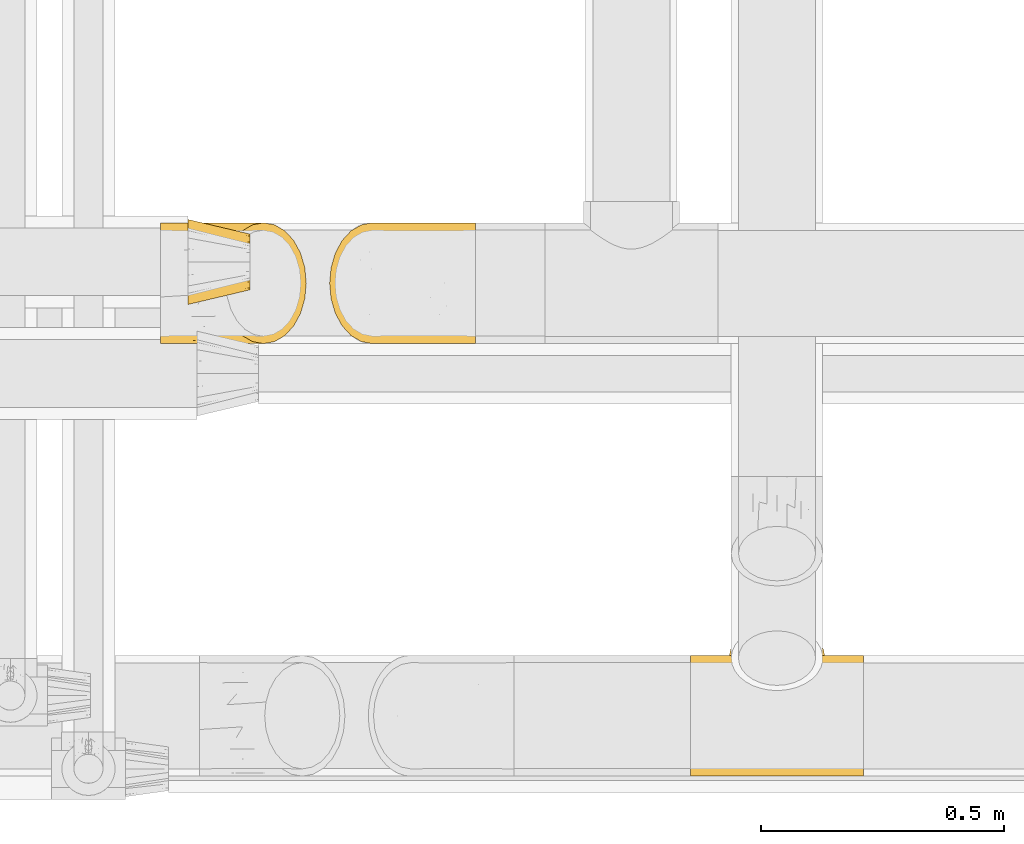
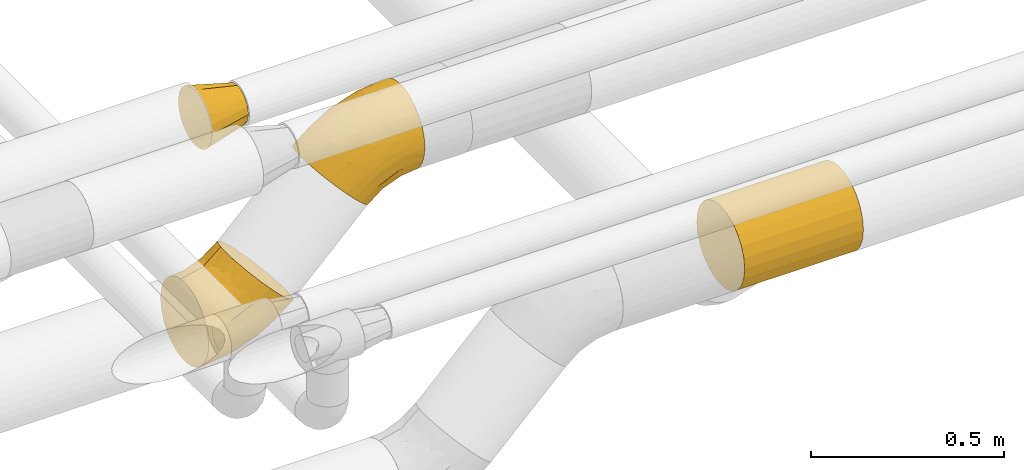
# One storey, part 186 of 827: 4 coverings.
"""IFC2X3 building model written with IfcOpenShell, lengths in millimetres."""

from ifc_helpers import new_model, entity, si_unit, converted_unit, derived_unit, direction, frame, origin, place, context, subcontext, project, spatial, faceted_brep, element, save


model = new_model("IFC2X3")

# Units and contexts
model_context = context("Model", 3, precision=0.01, world=origin(), true_north=direction((6.12303176911189e-17, 1.0)))
body_context = subcontext(model_context, "Body", "Model", "MODEL_VIEW")
ifc_project = project(units=[si_unit("LENGTHUNIT", "METRE", prefix="MILLI"), si_unit("AREAUNIT", "SQUARE_METRE"), si_unit("VOLUMEUNIT", "CUBIC_METRE"), converted_unit("PLANEANGLEUNIT", "DEGREE", entity("IfcRatioMeasure", 0.0174532925199433), si_unit("PLANEANGLEUNIT", "RADIAN"), dimensions=[0, 0, 0, 0, 0, 0, 0]), si_unit("MASSUNIT", "GRAM", prefix="KILO"), derived_unit("MASSDENSITYUNIT", [(si_unit("MASSUNIT", "GRAM", prefix="KILO"), 1), (si_unit("LENGTHUNIT", "METRE"), -3)]), derived_unit("MOMENTOFINERTIAUNIT", [(si_unit("LENGTHUNIT", "METRE"), 4)]), si_unit("TIMEUNIT", "SECOND"), si_unit("FREQUENCYUNIT", "HERTZ"), si_unit("THERMODYNAMICTEMPERATUREUNIT", "DEGREE_CELSIUS"), derived_unit("THERMALTRANSMITTANCEUNIT", [(si_unit("MASSUNIT", "GRAM", prefix="KILO"), 1), (si_unit("THERMODYNAMICTEMPERATUREUNIT", "KELVIN"), -1), (si_unit("TIMEUNIT", "SECOND"), -3)]), derived_unit("VOLUMETRICFLOWRATEUNIT", [(si_unit("LENGTHUNIT", "METRE"), 3), (si_unit("TIMEUNIT", "SECOND"), -1)]), derived_unit("MASSFLOWRATEUNIT", [(si_unit("MASSUNIT", "GRAM", prefix="KILO"), 1), (si_unit("TIMEUNIT", "SECOND"), -1)]), derived_unit("ROTATIONALFREQUENCYUNIT", [(si_unit("TIMEUNIT", "SECOND"), -1)]), si_unit("ELECTRICCURRENTUNIT", "AMPERE"), si_unit("ELECTRICVOLTAGEUNIT", "VOLT"), si_unit("POWERUNIT", "WATT"), si_unit("FORCEUNIT", "NEWTON", prefix="KILO"), si_unit("ILLUMINANCEUNIT", "LUX"), si_unit("LUMINOUSFLUXUNIT", "LUMEN"), si_unit("LUMINOUSINTENSITYUNIT", "CANDELA"), derived_unit("USERDEFINED", [(si_unit("MASSUNIT", "GRAM", prefix="KILO"), -1), (si_unit("LENGTHUNIT", "METRE"), -2), (si_unit("TIMEUNIT", "SECOND"), 3), (si_unit("LUMINOUSFLUXUNIT", "LUMEN"), 1)]), derived_unit("LINEARVELOCITYUNIT", [(si_unit("LENGTHUNIT", "METRE"), 1), (si_unit("TIMEUNIT", "SECOND"), -1)]), si_unit("PRESSUREUNIT", "PASCAL"), derived_unit("USERDEFINED", [(si_unit("LENGTHUNIT", "METRE"), -2), (si_unit("MASSUNIT", "GRAM", prefix="KILO"), 1), (si_unit("TIMEUNIT", "SECOND"), -2)]), derived_unit("LINEARFORCEUNIT", [(si_unit("MASSUNIT", "GRAM", prefix="KILO"), 1), (si_unit("LENGTHUNIT", "METRE"), 1), (si_unit("TIMEUNIT", "SECOND"), -2), (si_unit("LENGTHUNIT", "METRE"), -1)]), derived_unit("PLANARFORCEUNIT", [(si_unit("MASSUNIT", "GRAM", prefix="KILO"), 1), (si_unit("LENGTHUNIT", "METRE"), 1), (si_unit("TIMEUNIT", "SECOND"), -2), (si_unit("LENGTHUNIT", "METRE"), -2)])], contexts=[model_context])

# Site, building, storey
site_placement = place(None, origin())
site = spatial("IfcSite", under=ifc_project, at=site_placement, CompositionType="ELEMENT")
building_placement = place(site_placement, origin())
building = spatial("IfcBuilding", under=site, at=building_placement, CompositionType="ELEMENT")
storey_placement = place(building_placement, frame((0.0, 0.0, 28200.0)))
storey = spatial("IfcBuildingStorey", under=building, at=storey_placement, Name="08", CompositionType="ELEMENT", Elevation=28200.0)

# Coverings
covering_1_placement = place(storey_placement, frame((36776.59, 7140.11, 2373.87)))
element("IfcCovering", 1, at=covering_1_placement, inside=storey, Name=":ADSK_", ObjectType=":ADSK_", PredefinedType="INSULATION", context=body_context, shape_type="Brep", body=[
    faceted_brep([(1.6, 182.62, 237.02), (1.6, 199.28, 226.82), (1.6, 214.13, 214.13), (1.6, 226.82, 199.27), (1.6, 237.03, 182.61), (1.6, 244.5, 164.56), (1.6, 249.06, 145.56), (1.6, 250.6, 126.1), (1.6, 249.06, 106.62), (1.6, 244.5, 87.62), (1.6, 237.02, 69.57), (1.6, 226.82, 52.91), (1.6, 214.13, 38.06), (1.6, 199.27, 25.37), (1.6, 182.61, 15.16), (1.6, 164.56, 7.69), (1.6, 145.56, 3.13), (1.6, 126.1, 1.6), (1.6, 106.62, 3.13), (1.6, 87.62, 7.69), (1.6, 69.57, 15.17), (1.6, 52.91, 25.37), (1.6, 38.06, 38.06), (1.6, 25.37, 52.92), (1.6, 15.16, 69.58), (1.6, 7.69, 87.63), (1.6, 3.13, 106.63), (1.6, 1.6, 126.1), (1.6, 3.13, 145.57), (1.6, 7.69, 164.57), (1.6, 15.17, 182.62), (1.6, 25.37, 199.28), (1.6, 38.06, 214.13), (1.6, 52.92, 226.82), (1.6, 69.58, 237.03), (1.6, 87.63, 244.5), (1.6, 106.63, 249.06), (1.6, 126.1, 250.6), (1.6, 145.57, 249.06), (1.6, 164.57, 244.5), (151.48, 38.06, 276.21), (169.71, 18.28, 257.98), (190.94, 5.84, 236.74), (213.72, 1.6, 213.96), (236.51, 5.84, 191.17), (257.74, 18.28, 169.94), (275.97, 38.06, 151.7), (289.96, 63.85, 137.71), (298.76, 93.87, 128.92), (301.76, 126.1, 125.92), (298.76, 158.32, 128.92), (289.96, 188.35, 137.71), (275.97, 214.13, 151.7), (257.74, 233.92, 169.94), (236.51, 246.35, 191.17), (213.72, 250.6, 213.96), (190.94, 246.35, 236.74), (169.71, 233.92, 257.98), (151.48, 214.13, 276.21), (137.49, 188.35, 290.2), (128.69, 158.32, 298.99), (125.69, 126.1, 301.99), (128.69, 93.87, 298.99), (137.49, 63.85, 290.2), (227.52, 149.06, 69.23), (162.49, 157.57, 37.64), (232.64, 172.62, 80.77), (251.11, 126.1, 82.66), (87.26, 172.54, 19.51), (88.51, 205.38, 39.76), (72.31, 228.86, 62.63), (169.79, 211.39, 73.46), (132.77, 126.1, 22.37), (194.31, 126.1, 47.86), (68.0, 126.1, 6.82), (94.59, 148.92, 14.07), (224.13, 196.14, 90.2), (156.45, 188.53, 48.93), (159.73, 241.93, 118.76), (81.73, 239.97, 85.05), (98.75, 247.93, 115.3), (213.5, 224.58, 115.3), (141.47, 229.78, 84.72), (164.84, 248.4, 147.07), (116.4, 250.6, 148.93), (168.26, 250.6, 176.65), (60.12, 250.6, 131.86), (144.59, 243.25, 211.49), (102.29, 247.16, 174.55), (94.09, 237.03, 200.86), (105.16, 219.17, 235.05), (127.13, 232.82, 226.38), (45.12, 175.8, 245.41), (69.55, 148.67, 262.05), (92.2, 170.51, 266.3), (54.34, 243.33, 173.44), (107.8, 189.91, 264.82), (76.0, 195.3, 244.22), (38.6, 195.29, 233.11), (89.35, 126.1, 274.11), (53.39, 223.78, 209.38), (47.02, 126.1, 256.57), (56.49, 99.35, 256.34), (95.02, 94.07, 272.6), (135.64, 8.49, 204.31), (116.4, 1.6, 148.93), (168.26, 1.6, 176.65), (131.4, 25.02, 239.5), (87.85, 26.42, 217.85), (101.5, 48.04, 249.38), (50.41, 42.36, 224.04), (74.53, 74.96, 254.46), (36.95, 76.79, 243.81), (108.87, 73.49, 272.72), (74.1, 8.09, 176.09), (45.75, 25.62, 203.96), (60.12, 1.6, 131.86), (159.72, 10.26, 118.76), (213.49, 27.6, 115.3), (169.79, 40.79, 73.47), (224.15, 56.04, 90.21), (164.83, 3.79, 147.07), (98.75, 4.26, 115.3), (227.52, 103.13, 69.23), (88.51, 46.81, 39.76), (156.45, 63.66, 48.94), (232.64, 79.57, 80.78), (162.49, 94.61, 37.64), (141.47, 22.4, 84.73), (94.58, 103.26, 14.07), (87.27, 79.64, 19.51), (72.31, 23.32, 62.64), (81.73, 12.22, 85.06)], [[[0, 1, 2, 3, 4, 5, 6, 7, 8, 9, 10, 11, 12, 13, 14, 15, 16, 17, 18, 19, 20, 21, 22, 23, 24, 25, 26, 27, 28, 29, 30, 31, 32, 33, 34, 35, 36, 37, 38, 39]], [[40, 41, 42, 43, 44, 45, 46, 47, 48, 49, 50, 51, 52, 53, 54, 55, 56, 57, 58, 59, 60, 61, 62, 63]], [[64, 65, 66]], [[67, 50, 49]], [[68, 14, 13]], [[69, 70, 71]], [[72, 65, 73]], [[72, 74, 75]], [[13, 12, 69]], [[64, 73, 65]], [[70, 12, 11]], [[76, 66, 77]], [[78, 79, 80]], [[53, 81, 78]], [[78, 82, 79]], [[80, 9, 8]], [[76, 77, 71]], [[55, 54, 83]], [[78, 80, 83]], [[68, 69, 77]], [[77, 69, 71]], [[84, 85, 83]], [[14, 68, 15]], [[77, 65, 68]], [[69, 68, 13]], [[75, 68, 65]], [[78, 81, 82]], [[70, 69, 12]], [[68, 75, 15]], [[16, 74, 17]], [[51, 66, 76]], [[76, 71, 81]], [[52, 76, 81]], [[52, 81, 53]], [[86, 8, 7]], [[84, 80, 86]], [[80, 84, 83]], [[51, 50, 66]], [[64, 50, 67]], [[82, 70, 79]], [[81, 71, 82]], [[86, 80, 8]], [[76, 52, 51]], [[79, 10, 9]], [[10, 79, 70]], [[53, 78, 54]], [[77, 66, 65]], [[75, 16, 15]], [[72, 75, 65]], [[80, 79, 9]], [[16, 75, 74]], [[70, 82, 71]], [[10, 70, 11]], [[55, 83, 85]], [[54, 78, 83]], [[50, 64, 66]], [[73, 64, 67]], [[56, 85, 87]], [[56, 55, 85]], [[87, 85, 88]], [[89, 90, 91]], [[91, 58, 57]], [[91, 87, 89]], [[92, 93, 94]], [[38, 93, 92]], [[88, 95, 89]], [[96, 97, 94]], [[94, 97, 92]], [[98, 2, 1]], [[88, 85, 84]], [[99, 61, 60]], [[93, 60, 94]], [[59, 94, 60]], [[98, 0, 92]], [[38, 92, 39]], [[100, 4, 3]], [[87, 88, 89]], [[3, 2, 100]], [[100, 95, 4]], [[6, 95, 86]], [[98, 100, 2]], [[90, 97, 96]], [[5, 95, 6]], [[7, 6, 86]], [[93, 101, 99]], [[0, 98, 1]], [[60, 93, 99]], [[57, 56, 87]], [[37, 101, 38]], [[93, 38, 101]], [[86, 95, 88]], [[100, 90, 89]], [[0, 39, 92]], [[95, 100, 89]], [[90, 96, 58]], [[92, 97, 98]], [[90, 100, 97]], [[100, 98, 97]], [[5, 4, 95]], [[94, 59, 96]], [[86, 88, 84]], [[96, 59, 58]], [[58, 91, 90]], [[57, 87, 91]], [[102, 103, 99]], [[104, 105, 106]], [[102, 99, 101]], [[104, 107, 108]], [[109, 107, 40]], [[103, 61, 99]], [[110, 111, 112]], [[109, 111, 110]], [[36, 102, 101]], [[113, 103, 111]], [[114, 104, 108]], [[43, 42, 106]], [[104, 42, 41]], [[63, 109, 40]], [[109, 108, 107]], [[106, 42, 104]], [[104, 41, 107]], [[104, 114, 105]], [[36, 35, 102]], [[30, 115, 31]], [[115, 30, 114]], [[41, 40, 107]], [[34, 112, 35]], [[35, 112, 102]], [[33, 110, 112]], [[113, 62, 103]], [[115, 110, 32]], [[31, 115, 32]], [[116, 114, 29]], [[33, 32, 110]], [[110, 115, 108]], [[114, 30, 29]], [[109, 110, 108]], [[114, 116, 105]], [[112, 111, 102]], [[102, 111, 103]], [[28, 27, 116]], [[29, 28, 116]], [[113, 109, 63]], [[112, 34, 33]], [[109, 113, 111]], [[36, 101, 37]], [[62, 113, 63]], [[103, 62, 61]], [[114, 108, 115]], [[117, 45, 44]], [[117, 118, 45]], [[118, 119, 120]], [[121, 122, 117]], [[73, 67, 123]], [[119, 124, 125]], [[122, 121, 105]], [[106, 121, 43]], [[123, 126, 127]], [[118, 128, 119]], [[67, 49, 48]], [[129, 130, 19]], [[46, 120, 47]], [[125, 127, 126]], [[48, 126, 123]], [[73, 127, 72]], [[19, 18, 129]], [[131, 119, 128]], [[126, 48, 47]], [[130, 20, 19]], [[24, 132, 25]], [[126, 47, 120]], [[116, 27, 26]], [[131, 22, 124]], [[118, 46, 45]], [[132, 122, 25]], [[132, 131, 128]], [[121, 106, 105]], [[117, 128, 118]], [[131, 24, 23]], [[125, 126, 120]], [[124, 22, 21]], [[124, 21, 130]], [[130, 21, 20]], [[26, 122, 116]], [[129, 18, 74]], [[127, 130, 129]], [[132, 117, 122]], [[17, 74, 18]], [[127, 125, 130]], [[124, 130, 125]], [[127, 129, 72]], [[122, 105, 116]], [[46, 118, 120]], [[132, 128, 117]], [[25, 122, 26]], [[120, 119, 125]], [[119, 131, 124]], [[72, 129, 74]], [[24, 131, 132]], [[131, 23, 22]], [[117, 44, 121]], [[43, 121, 44]], [[73, 123, 127]], [[48, 123, 67]]]),
])
covering_2_placement = place(storey_placement, frame((37124.89, 7140.11, 2722.38)))
element("IfcCovering", 2, at=covering_2_placement, inside=storey, Name=":ADSK_", ObjectType=":ADSK_", PredefinedType="INSULATION", context=body_context, shape_type="Brep", body=[
    faceted_brep([(301.76, 164.57, 59.09), (301.76, 182.62, 66.57), (301.76, 199.28, 76.77), (301.76, 214.13, 89.46), (301.77, 226.82, 104.32), (301.77, 237.03, 120.98), (301.77, 244.5, 139.03), (301.77, 249.06, 158.03), (301.77, 250.6, 177.49), (301.77, 249.06, 196.97), (301.77, 244.5, 215.97), (301.77, 237.02, 234.02), (301.77, 226.82, 250.68), (301.77, 214.13, 265.53), (301.77, 199.27, 278.22), (301.77, 182.61, 288.43), (301.78, 164.56, 295.9), (301.78, 145.56, 300.46), (301.78, 126.1, 301.99), (301.78, 106.62, 300.46), (301.78, 87.62, 295.9), (301.77, 69.57, 288.42), (301.77, 52.91, 278.21), (301.77, 38.06, 265.53), (301.77, 25.37, 250.67), (301.77, 15.16, 234.01), (301.77, 7.69, 215.96), (301.77, 3.13, 196.96), (301.77, 1.6, 177.49), (301.77, 3.13, 158.02), (301.77, 7.69, 139.02), (301.77, 15.17, 120.97), (301.77, 25.37, 104.31), (301.76, 38.06, 89.46), (301.76, 52.92, 76.77), (301.76, 69.58, 66.56), (301.76, 87.63, 59.09), (301.76, 106.63, 54.53), (301.76, 126.1, 52.99), (301.76, 145.57, 54.53), (151.88, 38.06, 27.38), (133.64, 18.28, 45.61), (112.41, 5.84, 66.85), (89.63, 1.6, 89.63), (66.84, 5.84, 112.42), (45.61, 18.28, 133.65), (27.38, 38.06, 151.88), (13.39, 63.85, 165.88), (4.59, 93.87, 174.67), (1.6, 126.1, 177.67), (4.59, 158.32, 174.67), (13.39, 188.35, 165.88), (27.38, 214.13, 151.88), (45.61, 233.92, 133.65), (66.84, 246.35, 112.42), (89.63, 250.6, 89.63), (112.41, 246.35, 66.85), (133.64, 233.92, 45.61), (151.88, 214.13, 27.38), (165.87, 188.35, 13.39), (174.66, 158.32, 4.6), (177.66, 126.1, 1.6), (174.66, 93.87, 4.6), (165.87, 63.85, 13.39), (75.84, 149.06, 234.36), (140.87, 157.57, 265.95), (70.72, 172.62, 222.82), (52.25, 126.1, 220.93), (216.1, 172.54, 284.08), (214.86, 205.38, 263.84), (231.06, 228.86, 240.96), (133.57, 211.39, 230.13), (170.59, 126.1, 281.22), (109.05, 126.1, 255.73), (235.37, 126.1, 296.77), (208.77, 148.92, 289.52), (79.23, 196.14, 213.4), (146.91, 188.53, 254.66), (143.63, 241.93, 184.84), (221.63, 239.97, 218.55), (204.61, 247.93, 188.29), (89.86, 224.58, 188.29), (161.89, 229.78, 218.87), (138.52, 248.4, 156.52), (186.96, 250.6, 154.66), (135.09, 250.6, 126.94), (243.24, 250.6, 171.73), (158.76, 243.25, 92.1), (201.07, 247.16, 129.05), (209.27, 237.03, 102.74), (198.2, 219.17, 68.55), (176.22, 232.82, 77.21), (258.24, 175.8, 58.18), (233.81, 148.66, 41.54), (211.15, 170.51, 37.29), (249.02, 243.33, 130.15), (195.55, 189.91, 38.77), (227.35, 195.3, 59.37), (264.76, 195.29, 70.48), (214.01, 126.1, 29.49), (249.97, 223.78, 94.21), (256.34, 126.1, 47.02), (246.86, 99.35, 47.25), (208.34, 94.07, 30.99), (167.71, 8.49, 99.29), (186.96, 1.6, 154.66), (135.09, 1.6, 126.94), (171.95, 25.02, 64.09), (215.5, 26.42, 85.74), (201.86, 48.04, 54.22), (252.95, 42.36, 79.55), (228.83, 74.96, 49.13), (266.4, 76.79, 59.78), (194.49, 73.49, 30.87), (229.27, 8.09, 127.51), (257.61, 25.62, 99.63), (243.24, 1.6, 171.73), (143.64, 10.26, 184.83), (89.87, 27.6, 188.29), (133.57, 40.79, 230.13), (79.21, 56.04, 213.38), (138.52, 3.79, 156.52), (204.62, 4.26, 188.29), (75.84, 103.13, 234.36), (214.86, 46.81, 263.83), (146.91, 63.66, 254.66), (70.71, 79.57, 222.81), (140.87, 94.61, 265.95), (161.89, 22.4, 218.86), (208.78, 103.26, 289.52), (216.1, 79.64, 284.08), (231.06, 23.32, 240.96), (221.64, 12.22, 218.54)], [[[0, 1, 2, 3, 4, 5, 6, 7, 8, 9, 10, 11, 12, 13, 14, 15, 16, 17, 18, 19, 20, 21, 22, 23, 24, 25, 26, 27, 28, 29, 30, 31, 32, 33, 34, 35, 36, 37, 38, 39]], [[40, 41, 42, 43, 44, 45, 46, 47, 48, 49, 50, 51, 52, 53, 54, 55, 56, 57, 58, 59, 60, 61, 62, 63]], [[64, 65, 66]], [[67, 50, 49]], [[68, 15, 14]], [[69, 70, 71]], [[72, 65, 73]], [[72, 74, 75]], [[14, 13, 69]], [[64, 73, 65]], [[70, 13, 12]], [[76, 66, 77]], [[78, 79, 80]], [[53, 81, 78]], [[78, 82, 79]], [[80, 10, 9]], [[76, 77, 71]], [[55, 54, 83]], [[78, 80, 83]], [[68, 69, 77]], [[77, 69, 71]], [[84, 85, 83]], [[15, 68, 16]], [[77, 65, 68]], [[69, 68, 14]], [[75, 68, 65]], [[78, 81, 82]], [[70, 69, 13]], [[68, 75, 16]], [[17, 74, 18]], [[51, 66, 76]], [[76, 71, 81]], [[52, 76, 81]], [[52, 81, 53]], [[86, 9, 8]], [[84, 80, 86]], [[80, 84, 83]], [[51, 50, 66]], [[64, 50, 67]], [[82, 70, 79]], [[81, 71, 82]], [[86, 80, 9]], [[76, 52, 51]], [[79, 11, 10]], [[11, 79, 70]], [[53, 78, 54]], [[77, 66, 65]], [[75, 17, 16]], [[72, 75, 65]], [[80, 79, 10]], [[17, 75, 74]], [[70, 82, 71]], [[11, 70, 12]], [[55, 83, 85]], [[54, 78, 83]], [[50, 64, 66]], [[73, 64, 67]], [[56, 85, 87]], [[56, 55, 85]], [[87, 85, 88]], [[89, 90, 91]], [[91, 58, 57]], [[91, 87, 89]], [[92, 93, 94]], [[39, 93, 92]], [[88, 95, 89]], [[96, 97, 94]], [[94, 97, 92]], [[98, 3, 2]], [[88, 85, 84]], [[99, 61, 60]], [[93, 60, 94]], [[59, 94, 60]], [[98, 1, 92]], [[39, 92, 0]], [[100, 5, 4]], [[87, 88, 89]], [[4, 3, 100]], [[100, 95, 5]], [[7, 95, 86]], [[98, 100, 3]], [[90, 97, 96]], [[6, 95, 7]], [[8, 7, 86]], [[93, 101, 99]], [[1, 98, 2]], [[60, 93, 99]], [[57, 56, 87]], [[38, 101, 39]], [[93, 39, 101]], [[86, 95, 88]], [[100, 90, 89]], [[1, 0, 92]], [[95, 100, 89]], [[90, 96, 58]], [[92, 97, 98]], [[90, 100, 97]], [[100, 98, 97]], [[6, 5, 95]], [[94, 59, 96]], [[86, 88, 84]], [[96, 59, 58]], [[58, 91, 90]], [[57, 87, 91]], [[102, 103, 99]], [[104, 105, 106]], [[102, 99, 101]], [[104, 107, 108]], [[109, 107, 40]], [[103, 61, 99]], [[110, 111, 112]], [[109, 111, 110]], [[37, 102, 101]], [[113, 103, 111]], [[114, 104, 108]], [[43, 42, 106]], [[104, 42, 41]], [[63, 109, 40]], [[109, 108, 107]], [[106, 42, 104]], [[104, 41, 107]], [[104, 114, 105]], [[37, 36, 102]], [[31, 115, 32]], [[115, 31, 114]], [[41, 40, 107]], [[35, 112, 36]], [[36, 112, 102]], [[34, 110, 112]], [[113, 62, 103]], [[115, 110, 33]], [[32, 115, 33]], [[116, 114, 30]], [[34, 33, 110]], [[110, 115, 108]], [[114, 31, 30]], [[109, 110, 108]], [[114, 116, 105]], [[112, 111, 102]], [[102, 111, 103]], [[29, 28, 116]], [[30, 29, 116]], [[113, 109, 63]], [[112, 35, 34]], [[109, 113, 111]], [[37, 101, 38]], [[62, 113, 63]], [[103, 62, 61]], [[114, 108, 115]], [[117, 45, 44]], [[117, 118, 45]], [[118, 119, 120]], [[121, 122, 117]], [[73, 67, 123]], [[119, 124, 125]], [[122, 121, 105]], [[106, 121, 43]], [[123, 126, 127]], [[118, 128, 119]], [[67, 49, 48]], [[129, 130, 20]], [[46, 120, 47]], [[125, 127, 126]], [[48, 126, 123]], [[73, 127, 72]], [[20, 19, 129]], [[131, 119, 128]], [[126, 48, 47]], [[130, 21, 20]], [[25, 132, 26]], [[126, 47, 120]], [[116, 28, 27]], [[131, 23, 124]], [[118, 46, 45]], [[132, 122, 26]], [[132, 131, 128]], [[121, 106, 105]], [[117, 128, 118]], [[131, 25, 24]], [[125, 126, 120]], [[124, 23, 22]], [[124, 22, 130]], [[130, 22, 21]], [[27, 122, 116]], [[129, 19, 74]], [[127, 130, 129]], [[132, 117, 122]], [[18, 74, 19]], [[127, 125, 130]], [[124, 130, 125]], [[127, 129, 72]], [[122, 105, 116]], [[46, 118, 120]], [[132, 128, 117]], [[26, 122, 27]], [[120, 119, 125]], [[119, 131, 124]], [[72, 129, 74]], [[25, 131, 132]], [[131, 24, 23]], [[117, 44, 121]], [[43, 121, 44]], [[73, 123, 127]], [[48, 123, 67]]]),
])
covering_3_placement = place(storey_placement, frame((37870.3, 6248.85, 2709.5)))
element("IfcCovering", 3, at=covering_3_placement, inside=storey, Name=":ADSK_", ObjectType=":ADSK_", PredefinedType="INSULATION", context=body_context, shape_type="Brep", body=[
    faceted_brep([(0.0, 5.84, 158.26), (0.0, 1.6, 190.5), (0.0, 5.84, 222.73), (0.0, 18.28, 252.77), (0.0, 38.08, 278.57), (0.0, 63.87, 298.36), (0.0, 93.91, 310.8), (0.0, 126.15, 315.05), (0.0, 158.38, 310.8), (0.0, 188.42, 298.36), (0.0, 214.22, 278.57), (0.0, 234.01, 252.77), (0.0, 246.45, 222.73), (0.0, 250.7, 190.5), (0.0, 248.57, 174.38), (0.0, 246.45, 158.26), (0.0, 240.23, 143.24), (0.0, 234.01, 128.22), (0.0, 224.11, 115.33), (0.0, 214.22, 102.43), (0.0, 201.32, 92.53), (0.0, 188.42, 82.64), (0.0, 173.4, 76.41), (0.0, 158.38, 70.19), (0.0, 142.26, 68.07), (0.0, 126.15, 65.95), (0.0, 93.91, 70.19), (0.0, 63.87, 82.64), (0.0, 38.08, 102.43), (0.0, 18.28, 128.22), (356.0, 188.42, 298.36), (356.0, 158.38, 310.8), (356.0, 126.15, 315.05), (356.0, 93.91, 310.8), (356.0, 63.87, 298.36), (356.0, 38.08, 278.57), (356.0, 18.28, 252.77), (356.0, 5.84, 222.73), (356.0, 1.6, 190.5), (356.0, 5.84, 158.26), (356.0, 18.28, 128.22), (356.0, 38.08, 102.43), (356.0, 63.87, 82.64), (356.0, 93.91, 70.19), (356.0, 126.15, 65.95), (356.0, 142.26, 68.07), (356.0, 158.38, 70.19), (356.0, 173.4, 76.41), (356.0, 188.42, 82.64), (356.0, 201.32, 92.53), (356.0, 214.22, 102.43), (356.0, 224.11, 115.33), (356.0, 234.01, 128.22), (356.0, 240.23, 143.24), (356.0, 246.45, 158.26), (356.0, 248.57, 174.38), (356.0, 250.7, 190.5), (356.0, 246.45, 222.73), (356.0, 234.01, 252.77), (356.0, 214.22, 278.57), (194.29, 249.83, 205.12), (178.0, 249.56, 207.31), (209.63, 250.4, 199.14), (236.25, 250.24, 179.88), (223.62, 250.7, 190.45), (247.52, 248.64, 167.98), (90.43, 240.73, 141.68), (275.79, 225.03, 114.77), (161.71, 249.83, 205.12), (146.37, 250.4, 199.14), (78.85, 214.22, 102.43), (80.21, 225.03, 114.77), (132.38, 250.7, 190.45), (119.75, 250.24, 179.88), (108.48, 248.64, 167.98), (257.37, 245.57, 155.12), (265.57, 240.73, 141.68), (277.15, 214.22, 102.43), (271.83, 233.91, 128.06), (98.63, 245.57, 155.12), (84.17, 233.91, 128.06), (271.83, 188.59, 82.73), (275.79, 201.87, 91.62), (257.37, 161.52, 71.08), (265.57, 174.96, 75.91), (247.52, 148.67, 68.0), (80.21, 201.87, 91.62), (84.17, 188.59, 82.73), (98.63, 161.52, 71.08), (108.48, 148.67, 68.0), (90.43, 174.96, 75.91), (236.25, 136.77, 66.4), (223.62, 126.2, 65.95), (209.63, 117.5, 66.25), (194.29, 111.52, 66.81), (178.0, 109.34, 67.09), (119.75, 136.77, 66.4), (132.38, 126.2, 65.95), (146.37, 117.5, 66.25), (161.71, 111.52, 66.81), (203.66, 312.66, 139.43), (227.57, 305.66, 132.42), (248.11, 294.51, 121.28), (263.87, 279.99, 106.76), (273.77, 263.08, 89.85), (277.15, 244.94, 71.7), (273.77, 226.79, 53.56), (263.87, 209.88, 36.65), (248.11, 195.36, 22.13), (227.57, 184.22, 10.99), (203.66, 177.22, 3.98), (178.0, 174.83, 1.6), (152.34, 177.22, 3.98), (128.42, 184.22, 10.99), (107.89, 195.36, 22.13), (92.13, 209.88, 36.65), (82.23, 226.79, 53.56), (78.85, 244.94, 71.7), (82.23, 263.08, 89.85), (92.13, 279.99, 106.76), (107.89, 294.51, 121.28), (128.42, 305.66, 132.42), (152.34, 312.66, 139.43), (178.0, 315.05, 141.81)], [[[0, 1, 2, 3, 4, 5, 6, 7, 8, 9, 10, 11, 12, 13, 14, 15, 16, 17, 18, 19, 20, 21, 22, 23, 24, 25, 26, 27, 28, 29]], [[30, 31, 32, 33, 34, 35, 36, 37, 38, 39, 40, 41, 42, 43, 44, 45, 46, 47, 48, 49, 50, 51, 52, 53, 54, 55, 56, 57, 58, 59]], [[5, 34, 33, 6]], [[6, 33, 32, 7]], [[35, 34, 5, 4]], [[8, 31, 30, 9]], [[9, 30, 59, 10]], [[7, 32, 31, 8]], [[11, 58, 57, 12]], [[60, 61, 57]], [[58, 11, 10, 59]], [[57, 62, 60]], [[56, 63, 64]], [[56, 55, 63]], [[63, 55, 65]], [[64, 62, 56]], [[66, 17, 16]], [[56, 62, 57]], [[67, 52, 51]], [[57, 61, 12]], [[61, 68, 12]], [[69, 13, 12]], [[70, 18, 71]], [[13, 72, 73]], [[72, 13, 69]], [[74, 15, 14]], [[73, 74, 14]], [[75, 53, 76]], [[69, 12, 68]], [[53, 75, 54]], [[76, 53, 52]], [[75, 65, 54]], [[54, 65, 55]], [[50, 77, 51]], [[18, 70, 19]], [[67, 78, 52]], [[67, 51, 77]], [[52, 78, 76]], [[74, 79, 15]], [[79, 16, 15]], [[16, 79, 66]], [[14, 13, 73]], [[80, 71, 17]], [[71, 18, 17]], [[80, 17, 66]], [[50, 49, 77]], [[70, 20, 19]], [[48, 81, 82]], [[82, 49, 48]], [[46, 83, 47]], [[84, 47, 83]], [[46, 85, 83]], [[48, 84, 81]], [[70, 86, 20]], [[86, 87, 21]], [[23, 88, 89]], [[21, 90, 22]], [[90, 21, 87]], [[22, 88, 23]], [[44, 91, 45]], [[91, 44, 92]], [[93, 92, 44]], [[44, 43, 93]], [[84, 48, 47]], [[26, 43, 42, 27]], [[94, 43, 95]], [[43, 94, 93]], [[26, 95, 43]], [[86, 21, 20]], [[42, 41, 28, 27]], [[96, 24, 89]], [[96, 97, 25]], [[85, 46, 45]], [[89, 24, 23]], [[24, 96, 25]], [[97, 98, 25]], [[98, 99, 26]], [[77, 49, 82]], [[95, 26, 99]], [[98, 26, 25]], [[88, 22, 90]], [[85, 45, 91]], [[29, 40, 39, 0]], [[0, 39, 38, 1]], [[41, 40, 29, 28]], [[2, 37, 36, 3]], [[3, 36, 35, 4]], [[1, 38, 37, 2]], [[100, 101, 102, 103, 104, 105, 106, 107, 108, 109, 110, 111, 112, 113, 114, 115, 116, 117, 118, 119, 120, 121, 122, 123]], [[67, 105, 104]], [[78, 104, 103]], [[75, 103, 102]], [[67, 77, 105]], [[76, 78, 103]], [[75, 76, 103]], [[67, 104, 78]], [[102, 65, 75]], [[65, 102, 63]], [[63, 102, 101]], [[64, 101, 100]], [[60, 100, 123]], [[63, 101, 64]], [[100, 60, 62]], [[62, 64, 100]], [[60, 123, 61]], [[68, 123, 122]], [[122, 121, 72]], [[120, 73, 121]], [[120, 74, 73]], [[61, 123, 68]], [[69, 68, 122]], [[122, 72, 69]], [[121, 73, 72]], [[79, 120, 119]], [[80, 119, 118]], [[71, 118, 117]], [[66, 79, 119]], [[71, 80, 118]], [[70, 71, 117]], [[66, 119, 80]], [[120, 79, 74]], [[86, 117, 116]], [[87, 116, 115]], [[88, 115, 114]], [[86, 70, 117]], [[90, 87, 115]], [[88, 90, 115]], [[86, 116, 87]], [[114, 89, 88]], [[89, 114, 96]], [[96, 114, 113]], [[97, 113, 112]], [[99, 112, 111]], [[96, 113, 97]], [[112, 99, 98]], [[98, 97, 112]], [[99, 111, 95]], [[94, 111, 110]], [[110, 109, 92]], [[108, 91, 109]], [[108, 85, 91]], [[95, 111, 94]], [[93, 94, 110]], [[110, 92, 93]], [[109, 91, 92]], [[83, 108, 107]], [[81, 107, 106]], [[82, 106, 105]], [[84, 83, 107]], [[82, 81, 106]], [[77, 82, 105]], [[84, 107, 81]], [[108, 83, 85]]]),
])
covering_4_placement = place(storey_placement, frame((36835.03, 7220.9, 3010.9)))
element("IfcCovering", 4, at=covering_4_placement, inside=storey, Name=":ADSK_", ObjectType=":ADSK_", PredefinedType="INSULATION", context=body_context, shape_type="Brep", body=[
    faceted_brep([(127.0, 111.1, 142.22), (127.0, 100.1, 144.41), (127.0, 89.1, 146.6), (127.0, 78.09, 144.41), (127.0, 67.09, 142.22), (127.0, 57.76, 135.99), (127.0, 48.44, 129.75), (127.0, 42.2, 120.43), (127.0, 35.97, 111.1), (127.0, 33.78, 100.1), (127.0, 31.6, 89.1), (127.0, 33.78, 78.09), (127.0, 35.97, 67.09), (127.0, 42.2, 57.76), (127.0, 48.44, 48.44), (127.0, 57.76, 42.2), (127.0, 67.09, 35.97), (127.0, 78.09, 33.78), (127.0, 89.1, 31.6), (127.0, 100.1, 33.78), (127.0, 111.1, 35.97), (127.0, 120.43, 42.2), (127.0, 129.75, 48.44), (127.0, 135.99, 57.76), (127.0, 142.22, 67.09), (127.0, 144.41, 78.09), (127.0, 146.6, 89.1), (127.0, 144.41, 100.1), (127.0, 142.22, 111.1), (127.0, 135.99, 120.43), (127.0, 129.75, 129.75), (127.0, 120.43, 135.99), (0.0, 89.1, 176.6), (0.0, 116.13, 172.31), (0.0, 140.53, 159.88), (0.0, 159.88, 140.53), (0.0, 172.31, 116.13), (0.0, 176.6, 89.1), (0.0, 172.31, 62.06), (0.0, 159.88, 37.66), (0.0, 140.53, 18.31), (0.0, 116.13, 5.88), (0.0, 89.1, 1.6), (0.0, 62.06, 5.88), (0.0, 37.66, 18.31), (0.0, 18.31, 37.66), (0.0, 5.88, 62.06), (0.0, 1.6, 89.1), (0.0, 5.88, 116.13), (0.0, 18.31, 140.53), (0.0, 37.66, 159.88), (0.0, 62.06, 172.31)], [[[0, 1, 2, 3, 4, 5, 6, 7, 8, 9, 10, 11, 12, 13, 14, 15, 16, 17, 18, 19, 20, 21, 22, 23, 24, 25, 26, 27, 28, 29, 30, 31]], [[32, 33, 34, 35, 36, 37, 38, 39, 40, 41, 42, 43, 44, 45, 46, 47, 48, 49, 50, 51]], [[42, 17, 43]], [[16, 44, 43]], [[45, 14, 13, 12]], [[15, 14, 44, 16]], [[46, 12, 11]], [[10, 47, 11]], [[17, 42, 18]], [[45, 12, 46]], [[11, 47, 46]], [[17, 16, 43]], [[14, 45, 44]], [[37, 25, 38]], [[24, 39, 38]], [[40, 22, 21, 20]], [[23, 22, 39, 24]], [[41, 20, 19]], [[18, 42, 19]], [[25, 37, 26]], [[40, 20, 41]], [[19, 42, 41]], [[25, 24, 38]], [[22, 40, 39]], [[32, 1, 33]], [[0, 34, 33]], [[35, 30, 29, 28]], [[31, 30, 34, 0]], [[36, 28, 27]], [[26, 37, 27]], [[1, 32, 2]], [[35, 28, 36]], [[27, 37, 36]], [[1, 0, 33]], [[30, 35, 34]], [[47, 9, 48]], [[8, 49, 48]], [[50, 6, 5, 4]], [[7, 6, 49, 8]], [[51, 4, 3]], [[2, 32, 3]], [[9, 47, 10]], [[50, 4, 51]], [[3, 32, 51]], [[9, 8, 48]], [[6, 50, 49]]]),
])

save(model, "model.ifc")
